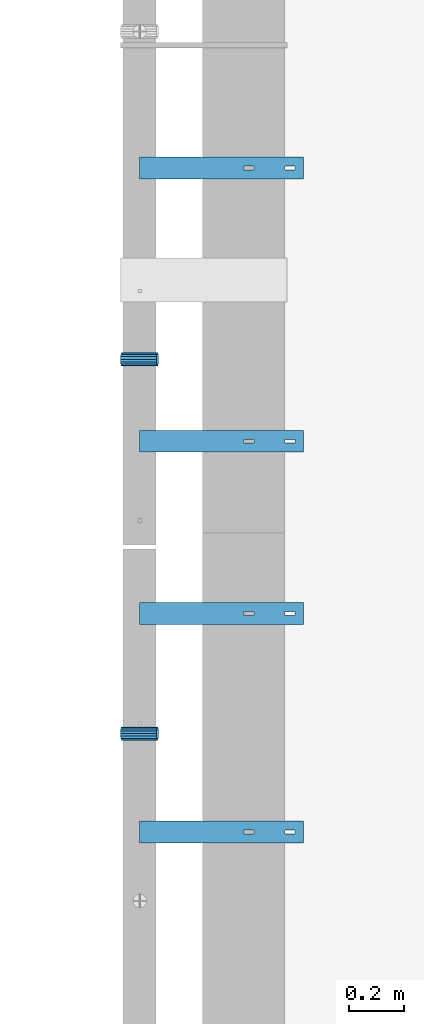
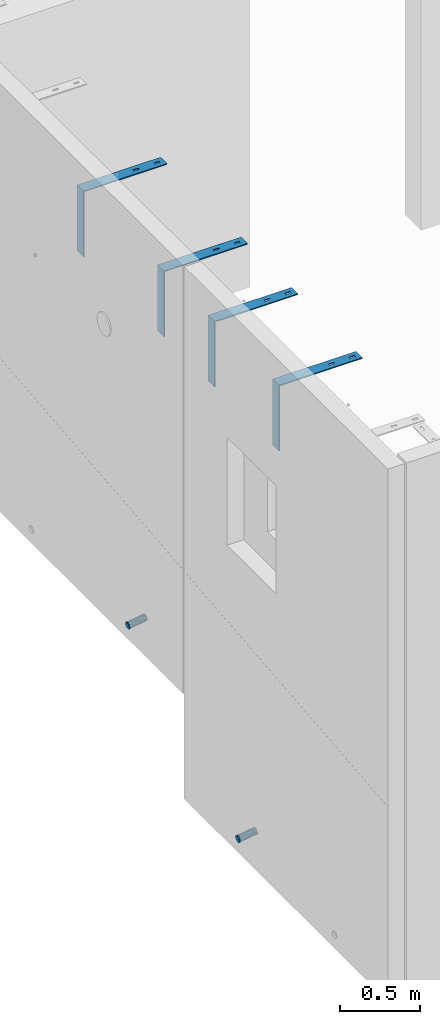
# One storey, part 85 of 264: 6 beams, 8 elements without a shape of their own.
"""IFC2X3 building model written with IfcOpenShell, lengths in millimetres."""

from ifc_helpers import new_model, si_unit, frame, origin_with_axes, place, context, subcontext, project, spatial, faceted_brep, material, type_object, element, aggregate, save


model = new_model("IFC2X3")

# Units and contexts
model_context = context("Model", 3, precision=1e-05, world=origin_with_axes())
body_context = subcontext(model_context, "Body", "Model", "MODEL_VIEW")
ifc_project = project(units=[si_unit("LENGTHUNIT", "METRE", prefix="MILLI"), si_unit("AREAUNIT", "SQUARE_METRE"), si_unit("VOLUMEUNIT", "CUBIC_METRE"), si_unit("MASSUNIT", "GRAM", prefix="KILO"), si_unit("TIMEUNIT", "SECOND"), si_unit("PLANEANGLEUNIT", "RADIAN"), si_unit("SOLIDANGLEUNIT", "STERADIAN"), si_unit("THERMODYNAMICTEMPERATUREUNIT", "DEGREE_CELSIUS"), si_unit("LUMINOUSINTENSITYUNIT", "LUMEN")], contexts=[model_context])

# Site, building, storey
site_placement = place(None, origin_with_axes())
site = spatial("IfcSite", under=ifc_project, at=site_placement, CompositionType="ELEMENT")
building_placement = place(site_placement, origin_with_axes())
building = spatial("IfcBuilding", under=site, at=building_placement, CompositionType="ELEMENT")
storey_placement = place(building_placement, origin_with_axes())
storey = spatial("IfcBuildingStorey", under=building, at=storey_placement, Name="K", CompositionType="ELEMENT", Elevation=0.0)

# Assemblies, beam
assembly_1_placement = place(storey_placement, origin_with_axes())
assembly_1 = element("IfcElementAssembly", 1, at=assembly_1_placement, inside=storey, AssemblyPlace="NOTDEFINED", PredefinedType="REINFORCEMENT_UNIT")
assembly_2_placement = place(assembly_1_placement, origin_with_axes())
assembly_2 = element("IfcElementAssembly", 2, at=assembly_2_placement, Name="Steel Assembly", AssemblyPlace="NOTDEFINED", PredefinedType="NOTDEFINED")
ifc_material_1 = material()
beam_type_1 = type_object("IfcBeamType", Name="D50", PredefinedType="NOTDEFINED")
beam_1_placement = place(assembly_2_placement, frame((7685.611109453, 13889.9999997536, 78614.7172983598), z_axis=(0.0, -1.0, 0.0), x_axis=(-0.988691934499859, -5.59999884149448e-08, -0.149960857075848)))
beam_1 = element("IfcBeam", 3, at=beam_1_placement, type_object=beam_type_1, material=ifc_material_1, ObjectType="D50", context=body_context, shape_type="Brep", body=[
    faceted_brep([(0.0, -25.0, 0.0), (-3.63797880709171e-12, -23.0969883127837, -9.56708580912891), (133.368135763521, -23.0969883127691, -9.56708580912709), (133.368135766923, -24.9999999999854, 1.81898940354586e-12), (-3.63797880709171e-12, -17.6776695296576, -17.6776695296649), (133.36813576064, -17.6776695296576, -17.677669529663), (-1.09139364212751e-11, -9.56708580913255, -23.0969883127837), (133.368135758712, -9.567085809118, -23.0969883127818), (-1.09139364212751e-11, 0.0, -25.0), (133.368135758034, 0.0, -25.0), (-1.09139364212751e-11, 9.56708580913255, -23.0969883127837), (133.36813575871, 9.56708580913255, -23.0969883127837), (-3.63797880709171e-12, 17.6776695296576, -17.6776695296649), (133.36813576064, 17.6776695296721, -17.677669529663), (-3.63797880709171e-12, 23.0969883127837, -9.56708580912891), (133.36813576352, 23.0969883127982, -9.56708580912709), (0.0, 25.0, 0.0), (133.368135766925, 25.0000000000146, -1.81898940354586e-12), (7.27595761418343e-12, 23.0969883127837, 9.56708580912891), (133.368135770323, 23.0969883127837, 9.56708580912709), (7.27595761418343e-12, 17.6776695296576, 17.6776695296649), (133.368135773204, 17.6776695296721, 17.6776695296649), (1.45519152283669e-11, 9.56708580913255, 23.0969883127837), (133.368135775132, 9.5670858091471, 23.0969883127837), (1.09139364212751e-11, 0.0, 25.0), (133.368135775807, 1.45519152283669e-11, 25.0), (1.45519152283669e-11, -9.56708580913255, 23.0969883127837), (133.368135775134, -9.56708580910345, 23.0969883127837), (7.27595761418343e-12, -17.6776695296576, 17.6776695296649), (133.368135773204, -17.6776695296721, 17.6776695296649), (7.27595761418343e-12, -23.0969883127837, 9.56708580912891), (133.368135770321, -23.0969883127691, 9.56708580912709)], [[[0, 1, 2, 3]], [[1, 4, 5, 2]], [[4, 6, 7, 5]], [[6, 8, 9, 7]], [[8, 10, 11, 9]], [[10, 12, 13, 11]], [[12, 14, 15, 13]], [[14, 16, 17, 15]], [[16, 18, 19, 17]], [[18, 20, 21, 19]], [[20, 22, 23, 21]], [[22, 24, 25, 23]], [[24, 26, 27, 25]], [[26, 28, 29, 27]], [[28, 30, 31, 29]], [[30, 0, 3, 31]], [[5, 7, 9, 11, 13, 15, 17, 19, 21, 23, 25, 27, 29, 31, 3, 2]], [[30, 28, 26, 24, 22, 20, 18, 16, 14, 12, 10, 8, 6, 4, 1, 0]]]),
])
aggregate(assembly_2, [beam_1])

assembly_3_placement = place(storey_placement, origin_with_axes())
assembly_3 = element("IfcElementAssembly", 4, at=assembly_3_placement, inside=storey, AssemblyPlace="NOTDEFINED", PredefinedType="REINFORCEMENT_UNIT")
assembly_4_placement = place(assembly_3_placement, origin_with_axes())
assembly_4 = element("IfcElementAssembly", 5, at=assembly_4_placement, Name="Steel Assembly", AssemblyPlace="NOTDEFINED", PredefinedType="NOTDEFINED")
beam_2_placement = place(assembly_4_placement, frame((7685.611109453, 12519.9999997536, 77824.7172983598), z_axis=(0.0, -1.0, 0.0), x_axis=(-0.988691934499859, -5.59999884149448e-08, -0.149960857075848)))
beam_2 = element("IfcBeam", 6, at=beam_2_placement, type_object=beam_type_1, material=ifc_material_1, ObjectType="D50", context=body_context, shape_type="Brep", body=[
    faceted_brep([(0.0, -25.0, 0.0), (-3.63797880709171e-12, -23.0969883127837, -9.56708580912891), (133.368135763521, -23.0969883127691, -9.56708580912709), (133.368135766923, -24.9999999999854, 1.81898940354586e-12), (-3.63797880709171e-12, -17.6776695296576, -17.6776695296649), (133.36813576064, -17.6776695296576, -17.677669529663), (-1.09139364212751e-11, -9.56708580913255, -23.0969883127837), (133.368135758712, -9.567085809118, -23.0969883127818), (-1.09139364212751e-11, 0.0, -25.0), (133.368135758034, 0.0, -25.0), (-1.09139364212751e-11, 9.56708580913255, -23.0969883127837), (133.36813575871, 9.56708580913255, -23.0969883127837), (-3.63797880709171e-12, 17.6776695296576, -17.6776695296649), (133.36813576064, 17.6776695296721, -17.677669529663), (-3.63797880709171e-12, 23.0969883127837, -9.56708580912891), (133.36813576352, 23.0969883127982, -9.56708580912709), (0.0, 25.0, 0.0), (133.368135766925, 25.0000000000146, -1.81898940354586e-12), (7.27595761418343e-12, 23.0969883127837, 9.56708580912891), (133.368135770323, 23.0969883127837, 9.56708580912709), (7.27595761418343e-12, 17.6776695296576, 17.6776695296649), (133.368135773204, 17.6776695296721, 17.6776695296649), (1.45519152283669e-11, 9.56708580913255, 23.0969883127837), (133.368135775132, 9.5670858091471, 23.0969883127837), (1.09139364212751e-11, 0.0, 25.0), (133.368135775807, 1.45519152283669e-11, 25.0), (1.45519152283669e-11, -9.56708580913255, 23.0969883127837), (133.368135775134, -9.56708580910345, 23.0969883127837), (7.27595761418343e-12, -17.6776695296576, 17.6776695296649), (133.368135773204, -17.6776695296721, 17.6776695296649), (7.27595761418343e-12, -23.0969883127837, 9.56708580912891), (133.368135770321, -23.0969883127691, 9.56708580912709)], [[[0, 1, 2, 3]], [[1, 4, 5, 2]], [[4, 6, 7, 5]], [[6, 8, 9, 7]], [[8, 10, 11, 9]], [[10, 12, 13, 11]], [[12, 14, 15, 13]], [[14, 16, 17, 15]], [[16, 18, 19, 17]], [[18, 20, 21, 19]], [[20, 22, 23, 21]], [[22, 24, 25, 23]], [[24, 26, 27, 25]], [[26, 28, 29, 27]], [[28, 30, 31, 29]], [[30, 0, 3, 31]], [[5, 7, 9, 11, 13, 15, 17, 19, 21, 23, 25, 27, 29, 31, 3, 2]], [[30, 28, 26, 24, 22, 20, 18, 16, 14, 12, 10, 8, 6, 4, 1, 0]]]),
])
aggregate(assembly_4, [beam_2])

# Assembly, beam
assembly_5_placement = place(assembly_1_placement, origin_with_axes())
assembly_5 = element("IfcElementAssembly", 7, at=assembly_5_placement, Name="Steel Assembly", AssemblyPlace="NOTDEFINED", PredefinedType="RIGID_FRAME")
ifc_material_2 = material(Name="STEEL/1.4301")
beam_type_2 = type_object("IfcBeamType", PredefinedType="NOTDEFINED")
beam_3_placement = place(assembly_5_placement, frame((7920.0, 14550.0, 81220.0), z_axis=(1.0, 0.0, 0.0), x_axis=(0.0, 1.0, 0.0)))
beam_3 = element("IfcBeam", 8, at=beam_3_placement, type_object=beam_type_2, material=ifc_material_2, Name="RST", context=body_context, shape_type="Brep", body=[
    faceted_brep([(41.9999999999854, 250.0, 119.999999999996), (41.9999999999854, 242.0, 119.999999999996), (37.9999999999854, 242.0, 119.999999999996), (37.9999999999854, 250.0, 119.999999999996), (36.4549150281109, 242.0, 119.755282581471), (36.4549150281109, 250.0, 119.755282581471), (35.0610737385232, 242.0, 119.045084971873), (35.0610737385232, 250.0, 119.045084971873), (33.9549150281109, 242.0, 117.93892626146), (33.9549150281109, 250.0, 117.93892626146), (33.244717418509, 242.0, 116.545084971873), (33.244717418509, 250.0, 116.545084971873), (32.9999999999854, 242.0, 114.999999999996), (32.9999999999854, 250.0, 114.999999999996), (32.9999999999854, 242.0, 84.9999999999964), (32.9999999999854, 250.0, 84.9999999999964), (33.244717418509, 242.0, 83.4549150281237), (33.244717418509, 250.0, 83.4549150281237), (33.9549150281109, 242.0, 82.0610737385359), (33.9549150281109, 250.0, 82.0610737385359), (35.0610737385232, 242.0, 80.9549150281237), (35.0610737385232, 250.0, 80.9549150281237), (36.4549150281109, 242.0, 80.2447174185218), (36.4549150281109, 250.0, 80.2447174185218), (37.9999999999854, 242.0, 79.9999999999964), (37.9999999999854, 250.0, 79.9999999999964), (41.9999999999854, 242.0, 79.9999999999964), (41.9999999999854, 250.0, 79.9999999999964), (43.54508497186, 242.0, 80.2447174185218), (43.54508497186, 250.0, 80.2447174185218), (44.9389262614477, 242.0, 80.9549150281237), (44.9389262614477, 250.0, 80.9549150281237), (46.04508497186, 242.0, 82.0610737385359), (46.04508497186, 250.0, 82.0610737385359), (46.7552825814619, 242.0, 83.4549150281237), (46.7552825814619, 250.0, 83.4549150281237), (46.9999999999854, 242.0, 84.9999999999964), (46.9999999999854, 250.0, 84.9999999999964), (46.9999999999854, 242.0, 114.999999999996), (46.9999999999854, 250.0, 114.999999999996), (46.7552825814619, 242.0, 116.545084971873), (46.7552825814619, 250.0, 116.545084971873), (46.04508497186, 242.0, 117.93892626146), (46.04508497186, 250.0, 117.93892626146), (44.9389262614477, 242.0, 119.045084971873), (44.9389262614477, 250.0, 119.045084971873), (43.54508497186, 242.0, 119.755282581471), (43.54508497186, 250.0, 119.755282581471), (0.0, -250.0, -292.0), (0.0, -250.0, -300.0), (80.0, -250.0, -300.0), (80.0, -250.0, -292.0), (0.0, 242.0, -292.0), (80.0, 242.0, -292.0), (0.0, 250.0, 300.0), (0.0, 242.0, 300.0), (80.0, 242.0, 300.0), (80.0, 250.0, 300.0), (0.0, 250.0, -300.0), (80.0, 250.0, -300.0), (46.9999999999854, 250.0, 264.999999999996), (46.7552825814619, 250.0, 266.545084971873), (46.04508497186, 250.0, 267.93892626146), (44.9389262614477, 250.0, 269.045084971873), (43.54508497186, 250.0, 269.755282581471), (41.9999999999854, 250.0, 269.999999999996), (37.9999999999854, 250.0, 269.999999999996), (36.4549150281109, 250.0, 269.755282581471), (35.0610737385232, 250.0, 269.045084971873), (33.9549150281109, 250.0, 267.93892626146), (33.244717418509, 250.0, 266.545084971873), (32.9999999999854, 250.0, 264.999999999996), (32.9999999999854, 250.0, 234.999999999996), (33.244717418509, 250.0, 233.454915028124), (33.9549150281109, 250.0, 232.061073738536), (35.0610737385232, 250.0, 230.954915028124), (36.4549150281109, 250.0, 230.244717418522), (37.9999999999854, 250.0, 229.999999999996), (41.9999999999854, 250.0, 229.999999999996), (43.54508497186, 250.0, 230.244717418522), (44.9389262614477, 250.0, 230.954915028124), (46.04508497186, 250.0, 232.061073738536), (46.7552825814619, 250.0, 233.454915028124), (46.9999999999854, 250.0, 234.999999999996), (46.04508497186, 242.0, 267.93892626146), (44.9389262614477, 242.0, 269.045084971873), (46.7552825814619, 242.0, 266.545084971873), (46.9999999999854, 242.0, 264.999999999996), (46.9999999999854, 242.0, 234.999999999996), (46.7552825814619, 242.0, 233.454915028124), (46.04508497186, 242.0, 232.061073738536), (44.9389262614477, 242.0, 230.954915028124), (43.54508497186, 242.0, 230.244717418522), (41.9999999999854, 242.0, 229.999999999996), (37.9999999999854, 242.0, 229.999999999996), (36.4549150281109, 242.0, 230.244717418522), (35.0610737385232, 242.0, 230.954915028124), (33.9549150281109, 242.0, 232.061073738536), (33.244717418509, 242.0, 233.454915028124), (32.9999999999854, 242.0, 234.999999999996), (32.9999999999854, 242.0, 264.999999999996), (33.244717418509, 242.0, 266.545084971873), (33.9549150281109, 242.0, 267.93892626146), (35.0610737385232, 242.0, 269.045084971873), (36.4549150281109, 242.0, 269.755282581471), (37.9999999999854, 242.0, 269.999999999996), (41.9999999999854, 242.0, 269.999999999996), (43.54508497186, 242.0, 269.755282581471)], [[[0, 1, 2, 3]], [[3, 2, 4, 5]], [[5, 4, 6, 7]], [[7, 6, 8, 9]], [[9, 8, 10, 11]], [[11, 10, 12, 13]], [[13, 12, 14, 15]], [[15, 14, 16, 17]], [[17, 16, 18, 19]], [[19, 18, 20, 21]], [[21, 20, 22, 23]], [[23, 22, 24, 25]], [[25, 24, 26, 27]], [[27, 26, 28, 29]], [[29, 28, 30, 31]], [[31, 30, 32, 33]], [[33, 32, 34, 35]], [[35, 34, 36, 37]], [[37, 36, 38, 39]], [[39, 38, 40, 41]], [[41, 40, 42, 43]], [[43, 42, 44, 45]], [[45, 44, 46, 47]], [[47, 46, 1, 0]], [[48, 49, 50, 51]], [[52, 48, 51, 53]], [[54, 55, 56, 57]], [[49, 48, 52, 55, 54, 58]], [[49, 58, 59, 50]], [[56, 53, 51, 50, 59, 57]], [[58, 54, 57, 59], [39, 41, 43, 45, 47, 0, 3, 5, 7, 9, 11, 13, 15, 17, 19, 21, 23, 25, 27, 29, 31, 33, 35, 37], [60, 61, 62, 63, 64, 65, 66, 67, 68, 69, 70, 71, 72, 73, 74, 75, 76, 77, 78, 79, 80, 81, 82, 83]], [[62, 84, 85, 63]], [[61, 86, 84, 62]], [[60, 87, 86, 61]], [[83, 88, 87, 60]], [[82, 89, 88, 83]], [[81, 90, 89, 82]], [[80, 91, 90, 81]], [[79, 92, 91, 80]], [[78, 93, 92, 79]], [[77, 94, 93, 78]], [[76, 95, 94, 77]], [[75, 96, 95, 76]], [[74, 97, 96, 75]], [[73, 98, 97, 74]], [[72, 99, 98, 73]], [[71, 100, 99, 72]], [[70, 101, 100, 71]], [[69, 102, 101, 70]], [[68, 103, 102, 69]], [[67, 104, 103, 68]], [[66, 105, 104, 67]], [[65, 106, 105, 66]], [[64, 107, 106, 65]], [[63, 85, 107, 64]], [[55, 52, 53, 56], [30, 28, 26, 24, 22, 20, 18, 16, 14, 12, 10, 8, 6, 4, 2, 1, 46, 44, 42, 40, 38, 36, 34, 32], [91, 92, 93, 94, 95, 96, 97, 98, 99, 100, 101, 102, 103, 104, 105, 106, 107, 85, 84, 86, 87, 88, 89, 90]]]),
])
aggregate(assembly_5, [beam_3])

# Assembly
assembly_6_placement = place(assembly_1_placement, origin_with_axes())
assembly_6 = element("IfcElementAssembly", 9, at=assembly_6_placement, Name="Steel Assembly", AssemblyPlace="NOTDEFINED", PredefinedType="RIGID_FRAME")

aggregate(assembly_1, [assembly_5, assembly_6, assembly_2])

# Beam
beam_4_placement = place(assembly_6_placement, frame((7920.0, 13550.0, 81220.0), z_axis=(1.0, 0.0, 0.0), x_axis=(0.0, 1.0, 0.0)))
beam_4 = element("IfcBeam", 10, at=beam_4_placement, type_object=beam_type_2, material=ifc_material_2, Name="RST", context=body_context, shape_type="Brep", body=[
    faceted_brep([(41.9999999999854, 250.0, 119.999999999996), (41.9999999999854, 242.0, 119.999999999996), (37.9999999999854, 242.0, 119.999999999996), (37.9999999999854, 250.0, 119.999999999996), (36.4549150281109, 242.0, 119.755282581471), (36.4549150281109, 250.0, 119.755282581471), (35.0610737385232, 242.0, 119.045084971873), (35.0610737385232, 250.0, 119.045084971873), (33.9549150281109, 242.0, 117.93892626146), (33.9549150281109, 250.0, 117.93892626146), (33.244717418509, 242.0, 116.545084971873), (33.244717418509, 250.0, 116.545084971873), (32.9999999999854, 242.0, 114.999999999996), (32.9999999999854, 250.0, 114.999999999996), (32.9999999999854, 242.0, 84.9999999999964), (32.9999999999854, 250.0, 84.9999999999964), (33.244717418509, 242.0, 83.4549150281237), (33.244717418509, 250.0, 83.4549150281237), (33.9549150281109, 242.0, 82.0610737385359), (33.9549150281109, 250.0, 82.0610737385359), (35.0610737385232, 242.0, 80.9549150281237), (35.0610737385232, 250.0, 80.9549150281237), (36.4549150281109, 242.0, 80.2447174185218), (36.4549150281109, 250.0, 80.2447174185218), (37.9999999999854, 242.0, 79.9999999999964), (37.9999999999854, 250.0, 79.9999999999964), (41.9999999999854, 242.0, 79.9999999999964), (41.9999999999854, 250.0, 79.9999999999964), (43.54508497186, 242.0, 80.2447174185218), (43.54508497186, 250.0, 80.2447174185218), (44.9389262614477, 242.0, 80.9549150281237), (44.9389262614477, 250.0, 80.9549150281237), (46.04508497186, 242.0, 82.0610737385359), (46.04508497186, 250.0, 82.0610737385359), (46.7552825814619, 242.0, 83.4549150281237), (46.7552825814619, 250.0, 83.4549150281237), (46.9999999999854, 242.0, 84.9999999999964), (46.9999999999854, 250.0, 84.9999999999964), (46.9999999999854, 242.0, 114.999999999996), (46.9999999999854, 250.0, 114.999999999996), (46.7552825814619, 242.0, 116.545084971873), (46.7552825814619, 250.0, 116.545084971873), (46.04508497186, 242.0, 117.93892626146), (46.04508497186, 250.0, 117.93892626146), (44.9389262614477, 242.0, 119.045084971873), (44.9389262614477, 250.0, 119.045084971873), (43.54508497186, 242.0, 119.755282581471), (43.54508497186, 250.0, 119.755282581471), (0.0, -250.0, -292.0), (0.0, -250.0, -300.0), (80.0, -250.0, -300.0), (80.0, -250.0, -292.0), (0.0, 242.0, -292.0), (80.0, 242.0, -292.0), (0.0, 250.0, 300.0), (0.0, 242.0, 300.0), (80.0, 242.0, 300.0), (80.0, 250.0, 300.0), (0.0, 250.0, -300.0), (80.0, 250.0, -300.0), (46.9999999999854, 250.0, 264.999999999996), (46.7552825814619, 250.0, 266.545084971873), (46.04508497186, 250.0, 267.93892626146), (44.9389262614477, 250.0, 269.045084971873), (43.54508497186, 250.0, 269.755282581471), (41.9999999999854, 250.0, 269.999999999996), (37.9999999999854, 250.0, 269.999999999996), (36.4549150281109, 250.0, 269.755282581471), (35.0610737385232, 250.0, 269.045084971873), (33.9549150281109, 250.0, 267.93892626146), (33.244717418509, 250.0, 266.545084971873), (32.9999999999854, 250.0, 264.999999999996), (32.9999999999854, 250.0, 234.999999999996), (33.244717418509, 250.0, 233.454915028124), (33.9549150281109, 250.0, 232.061073738536), (35.0610737385232, 250.0, 230.954915028124), (36.4549150281109, 250.0, 230.244717418522), (37.9999999999854, 250.0, 229.999999999996), (41.9999999999854, 250.0, 229.999999999996), (43.54508497186, 250.0, 230.244717418522), (44.9389262614477, 250.0, 230.954915028124), (46.04508497186, 250.0, 232.061073738536), (46.7552825814619, 250.0, 233.454915028124), (46.9999999999854, 250.0, 234.999999999996), (46.04508497186, 242.0, 267.93892626146), (44.9389262614477, 242.0, 269.045084971873), (46.7552825814619, 242.0, 266.545084971873), (46.9999999999854, 242.0, 264.999999999996), (46.9999999999854, 242.0, 234.999999999996), (46.7552825814619, 242.0, 233.454915028124), (46.04508497186, 242.0, 232.061073738536), (44.9389262614477, 242.0, 230.954915028124), (43.54508497186, 242.0, 230.244717418522), (41.9999999999854, 242.0, 229.999999999996), (37.9999999999854, 242.0, 229.999999999996), (36.4549150281109, 242.0, 230.244717418522), (35.0610737385232, 242.0, 230.954915028124), (33.9549150281109, 242.0, 232.061073738536), (33.244717418509, 242.0, 233.454915028124), (32.9999999999854, 242.0, 234.999999999996), (32.9999999999854, 242.0, 264.999999999996), (33.244717418509, 242.0, 266.545084971873), (33.9549150281109, 242.0, 267.93892626146), (35.0610737385232, 242.0, 269.045084971873), (36.4549150281109, 242.0, 269.755282581471), (37.9999999999854, 242.0, 269.999999999996), (41.9999999999854, 242.0, 269.999999999996), (43.54508497186, 242.0, 269.755282581471)], [[[0, 1, 2, 3]], [[3, 2, 4, 5]], [[5, 4, 6, 7]], [[7, 6, 8, 9]], [[9, 8, 10, 11]], [[11, 10, 12, 13]], [[13, 12, 14, 15]], [[15, 14, 16, 17]], [[17, 16, 18, 19]], [[19, 18, 20, 21]], [[21, 20, 22, 23]], [[23, 22, 24, 25]], [[25, 24, 26, 27]], [[27, 26, 28, 29]], [[29, 28, 30, 31]], [[31, 30, 32, 33]], [[33, 32, 34, 35]], [[35, 34, 36, 37]], [[37, 36, 38, 39]], [[39, 38, 40, 41]], [[41, 40, 42, 43]], [[43, 42, 44, 45]], [[45, 44, 46, 47]], [[47, 46, 1, 0]], [[48, 49, 50, 51]], [[52, 48, 51, 53]], [[54, 55, 56, 57]], [[49, 48, 52, 55, 54, 58]], [[49, 58, 59, 50]], [[56, 53, 51, 50, 59, 57]], [[58, 54, 57, 59], [39, 41, 43, 45, 47, 0, 3, 5, 7, 9, 11, 13, 15, 17, 19, 21, 23, 25, 27, 29, 31, 33, 35, 37], [60, 61, 62, 63, 64, 65, 66, 67, 68, 69, 70, 71, 72, 73, 74, 75, 76, 77, 78, 79, 80, 81, 82, 83]], [[62, 84, 85, 63]], [[61, 86, 84, 62]], [[60, 87, 86, 61]], [[83, 88, 87, 60]], [[82, 89, 88, 83]], [[81, 90, 89, 82]], [[80, 91, 90, 81]], [[79, 92, 91, 80]], [[78, 93, 92, 79]], [[77, 94, 93, 78]], [[76, 95, 94, 77]], [[75, 96, 95, 76]], [[74, 97, 96, 75]], [[73, 98, 97, 74]], [[72, 99, 98, 73]], [[71, 100, 99, 72]], [[70, 101, 100, 71]], [[69, 102, 101, 70]], [[68, 103, 102, 69]], [[67, 104, 103, 68]], [[66, 105, 104, 67]], [[65, 106, 105, 66]], [[64, 107, 106, 65]], [[63, 85, 107, 64]], [[55, 52, 53, 56], [30, 28, 26, 24, 22, 20, 18, 16, 14, 12, 10, 8, 6, 4, 2, 1, 46, 44, 42, 40, 38, 36, 34, 32], [91, 92, 93, 94, 95, 96, 97, 98, 99, 100, 101, 102, 103, 104, 105, 106, 107, 85, 84, 86, 87, 88, 89, 90]]]),
])

aggregate(assembly_6, [beam_4])

# Assembly, beam
assembly_7_placement = place(assembly_3_placement, origin_with_axes())
assembly_7 = element("IfcElementAssembly", 11, at=assembly_7_placement, Name="Steel Assembly", AssemblyPlace="NOTDEFINED", PredefinedType="RIGID_FRAME")
beam_5_placement = place(assembly_7_placement, frame((7920.0, 12920.0, 81220.0), z_axis=(1.0, 0.0, 0.0), x_axis=(0.0, 1.0, 0.0)))
beam_5 = element("IfcBeam", 12, at=beam_5_placement, type_object=beam_type_2, material=ifc_material_2, Name="RST", context=body_context, shape_type="Brep", body=[
    faceted_brep([(41.9999999999854, 250.0, 119.999999999996), (41.9999999999854, 242.0, 119.999999999996), (37.9999999999854, 242.0, 119.999999999996), (37.9999999999854, 250.0, 119.999999999996), (36.4549150281109, 242.0, 119.755282581471), (36.4549150281109, 250.0, 119.755282581471), (35.0610737385232, 242.0, 119.045084971873), (35.0610737385232, 250.0, 119.045084971873), (33.9549150281109, 242.0, 117.93892626146), (33.9549150281109, 250.0, 117.93892626146), (33.244717418509, 242.0, 116.545084971873), (33.244717418509, 250.0, 116.545084971873), (32.9999999999854, 242.0, 114.999999999996), (32.9999999999854, 250.0, 114.999999999996), (32.9999999999854, 242.0, 84.9999999999964), (32.9999999999854, 250.0, 84.9999999999964), (33.244717418509, 242.0, 83.4549150281237), (33.244717418509, 250.0, 83.4549150281237), (33.9549150281109, 242.0, 82.0610737385359), (33.9549150281109, 250.0, 82.0610737385359), (35.0610737385232, 242.0, 80.9549150281237), (35.0610737385232, 250.0, 80.9549150281237), (36.4549150281109, 242.0, 80.2447174185218), (36.4549150281109, 250.0, 80.2447174185218), (37.9999999999854, 242.0, 79.9999999999964), (37.9999999999854, 250.0, 79.9999999999964), (41.9999999999854, 242.0, 79.9999999999964), (41.9999999999854, 250.0, 79.9999999999964), (43.54508497186, 242.0, 80.2447174185218), (43.54508497186, 250.0, 80.2447174185218), (44.9389262614477, 242.0, 80.9549150281237), (44.9389262614477, 250.0, 80.9549150281237), (46.04508497186, 242.0, 82.0610737385359), (46.04508497186, 250.0, 82.0610737385359), (46.7552825814619, 242.0, 83.4549150281237), (46.7552825814619, 250.0, 83.4549150281237), (46.9999999999854, 242.0, 84.9999999999964), (46.9999999999854, 250.0, 84.9999999999964), (46.9999999999854, 242.0, 114.999999999996), (46.9999999999854, 250.0, 114.999999999996), (46.7552825814619, 242.0, 116.545084971873), (46.7552825814619, 250.0, 116.545084971873), (46.04508497186, 242.0, 117.93892626146), (46.04508497186, 250.0, 117.93892626146), (44.9389262614477, 242.0, 119.045084971873), (44.9389262614477, 250.0, 119.045084971873), (43.54508497186, 242.0, 119.755282581471), (43.54508497186, 250.0, 119.755282581471), (0.0, -250.0, -292.0), (0.0, -250.0, -300.0), (80.0, -250.0, -300.0), (80.0, -250.0, -292.0), (0.0, 242.0, -292.0), (80.0, 242.0, -292.0), (0.0, 250.0, 300.0), (0.0, 242.0, 300.0), (80.0, 242.0, 300.0), (80.0, 250.0, 300.0), (0.0, 250.0, -300.0), (80.0, 250.0, -300.0), (46.9999999999854, 250.0, 264.999999999996), (46.7552825814619, 250.0, 266.545084971873), (46.04508497186, 250.0, 267.93892626146), (44.9389262614477, 250.0, 269.045084971873), (43.54508497186, 250.0, 269.755282581471), (41.9999999999854, 250.0, 269.999999999996), (37.9999999999854, 250.0, 269.999999999996), (36.4549150281109, 250.0, 269.755282581471), (35.0610737385232, 250.0, 269.045084971873), (33.9549150281109, 250.0, 267.93892626146), (33.244717418509, 250.0, 266.545084971873), (32.9999999999854, 250.0, 264.999999999996), (32.9999999999854, 250.0, 234.999999999996), (33.244717418509, 250.0, 233.454915028124), (33.9549150281109, 250.0, 232.061073738536), (35.0610737385232, 250.0, 230.954915028124), (36.4549150281109, 250.0, 230.244717418522), (37.9999999999854, 250.0, 229.999999999996), (41.9999999999854, 250.0, 229.999999999996), (43.54508497186, 250.0, 230.244717418522), (44.9389262614477, 250.0, 230.954915028124), (46.04508497186, 250.0, 232.061073738536), (46.7552825814619, 250.0, 233.454915028124), (46.9999999999854, 250.0, 234.999999999996), (46.04508497186, 242.0, 267.93892626146), (44.9389262614477, 242.0, 269.045084971873), (46.7552825814619, 242.0, 266.545084971873), (46.9999999999854, 242.0, 264.999999999996), (46.9999999999854, 242.0, 234.999999999996), (46.7552825814619, 242.0, 233.454915028124), (46.04508497186, 242.0, 232.061073738536), (44.9389262614477, 242.0, 230.954915028124), (43.54508497186, 242.0, 230.244717418522), (41.9999999999854, 242.0, 229.999999999996), (37.9999999999854, 242.0, 229.999999999996), (36.4549150281109, 242.0, 230.244717418522), (35.0610737385232, 242.0, 230.954915028124), (33.9549150281109, 242.0, 232.061073738536), (33.244717418509, 242.0, 233.454915028124), (32.9999999999854, 242.0, 234.999999999996), (32.9999999999854, 242.0, 264.999999999996), (33.244717418509, 242.0, 266.545084971873), (33.9549150281109, 242.0, 267.93892626146), (35.0610737385232, 242.0, 269.045084971873), (36.4549150281109, 242.0, 269.755282581471), (37.9999999999854, 242.0, 269.999999999996), (41.9999999999854, 242.0, 269.999999999996), (43.54508497186, 242.0, 269.755282581471)], [[[0, 1, 2, 3]], [[3, 2, 4, 5]], [[5, 4, 6, 7]], [[7, 6, 8, 9]], [[9, 8, 10, 11]], [[11, 10, 12, 13]], [[13, 12, 14, 15]], [[15, 14, 16, 17]], [[17, 16, 18, 19]], [[19, 18, 20, 21]], [[21, 20, 22, 23]], [[23, 22, 24, 25]], [[25, 24, 26, 27]], [[27, 26, 28, 29]], [[29, 28, 30, 31]], [[31, 30, 32, 33]], [[33, 32, 34, 35]], [[35, 34, 36, 37]], [[37, 36, 38, 39]], [[39, 38, 40, 41]], [[41, 40, 42, 43]], [[43, 42, 44, 45]], [[45, 44, 46, 47]], [[47, 46, 1, 0]], [[48, 49, 50, 51]], [[52, 48, 51, 53]], [[54, 55, 56, 57]], [[49, 48, 52, 55, 54, 58]], [[49, 58, 59, 50]], [[56, 53, 51, 50, 59, 57]], [[58, 54, 57, 59], [39, 41, 43, 45, 47, 0, 3, 5, 7, 9, 11, 13, 15, 17, 19, 21, 23, 25, 27, 29, 31, 33, 35, 37], [60, 61, 62, 63, 64, 65, 66, 67, 68, 69, 70, 71, 72, 73, 74, 75, 76, 77, 78, 79, 80, 81, 82, 83]], [[62, 84, 85, 63]], [[61, 86, 84, 62]], [[60, 87, 86, 61]], [[83, 88, 87, 60]], [[82, 89, 88, 83]], [[81, 90, 89, 82]], [[80, 91, 90, 81]], [[79, 92, 91, 80]], [[78, 93, 92, 79]], [[77, 94, 93, 78]], [[76, 95, 94, 77]], [[75, 96, 95, 76]], [[74, 97, 96, 75]], [[73, 98, 97, 74]], [[72, 99, 98, 73]], [[71, 100, 99, 72]], [[70, 101, 100, 71]], [[69, 102, 101, 70]], [[68, 103, 102, 69]], [[67, 104, 103, 68]], [[66, 105, 104, 67]], [[65, 106, 105, 66]], [[64, 107, 106, 65]], [[63, 85, 107, 64]], [[55, 52, 53, 56], [30, 28, 26, 24, 22, 20, 18, 16, 14, 12, 10, 8, 6, 4, 2, 1, 46, 44, 42, 40, 38, 36, 34, 32], [91, 92, 93, 94, 95, 96, 97, 98, 99, 100, 101, 102, 103, 104, 105, 106, 107, 85, 84, 86, 87, 88, 89, 90]]]),
])
aggregate(assembly_7, [beam_5])

# Assembly
assembly_8_placement = place(assembly_3_placement, origin_with_axes())
assembly_8 = element("IfcElementAssembly", 13, at=assembly_8_placement, Name="Steel Assembly", AssemblyPlace="NOTDEFINED", PredefinedType="RIGID_FRAME")

aggregate(assembly_3, [assembly_7, assembly_8, assembly_4])

# Beam
beam_6_placement = place(assembly_8_placement, frame((7920.0, 12120.0, 81220.0), z_axis=(1.0, 0.0, 0.0), x_axis=(0.0, 1.0, 0.0)))
beam_6 = element("IfcBeam", 14, at=beam_6_placement, type_object=beam_type_2, material=ifc_material_2, Name="RST", context=body_context, shape_type="Brep", body=[
    faceted_brep([(41.9999999999854, 250.0, 119.999999999996), (41.9999999999854, 242.0, 119.999999999996), (37.9999999999854, 242.0, 119.999999999996), (37.9999999999854, 250.0, 119.999999999996), (36.4549150281109, 242.0, 119.755282581471), (36.4549150281109, 250.0, 119.755282581471), (35.0610737385232, 242.0, 119.045084971873), (35.0610737385232, 250.0, 119.045084971873), (33.9549150281109, 242.0, 117.93892626146), (33.9549150281109, 250.0, 117.93892626146), (33.244717418509, 242.0, 116.545084971873), (33.244717418509, 250.0, 116.545084971873), (32.9999999999854, 242.0, 114.999999999996), (32.9999999999854, 250.0, 114.999999999996), (32.9999999999854, 242.0, 84.9999999999964), (32.9999999999854, 250.0, 84.9999999999964), (33.244717418509, 242.0, 83.4549150281237), (33.244717418509, 250.0, 83.4549150281237), (33.9549150281109, 242.0, 82.0610737385359), (33.9549150281109, 250.0, 82.0610737385359), (35.0610737385232, 242.0, 80.9549150281237), (35.0610737385232, 250.0, 80.9549150281237), (36.4549150281109, 242.0, 80.2447174185218), (36.4549150281109, 250.0, 80.2447174185218), (37.9999999999854, 242.0, 79.9999999999964), (37.9999999999854, 250.0, 79.9999999999964), (41.9999999999854, 242.0, 79.9999999999964), (41.9999999999854, 250.0, 79.9999999999964), (43.54508497186, 242.0, 80.2447174185218), (43.54508497186, 250.0, 80.2447174185218), (44.9389262614477, 242.0, 80.9549150281237), (44.9389262614477, 250.0, 80.9549150281237), (46.04508497186, 242.0, 82.0610737385359), (46.04508497186, 250.0, 82.0610737385359), (46.7552825814619, 242.0, 83.4549150281237), (46.7552825814619, 250.0, 83.4549150281237), (46.9999999999854, 242.0, 84.9999999999964), (46.9999999999854, 250.0, 84.9999999999964), (46.9999999999854, 242.0, 114.999999999996), (46.9999999999854, 250.0, 114.999999999996), (46.7552825814619, 242.0, 116.545084971873), (46.7552825814619, 250.0, 116.545084971873), (46.04508497186, 242.0, 117.93892626146), (46.04508497186, 250.0, 117.93892626146), (44.9389262614477, 242.0, 119.045084971873), (44.9389262614477, 250.0, 119.045084971873), (43.54508497186, 242.0, 119.755282581471), (43.54508497186, 250.0, 119.755282581471), (0.0, -250.0, -292.0), (0.0, -250.0, -300.0), (80.0, -250.0, -300.0), (80.0, -250.0, -292.0), (0.0, 242.0, -292.0), (80.0, 242.0, -292.0), (0.0, 250.0, 300.0), (0.0, 242.0, 300.0), (80.0, 242.0, 300.0), (80.0, 250.0, 300.0), (0.0, 250.0, -300.0), (80.0, 250.0, -300.0), (46.9999999999854, 250.0, 264.999999999996), (46.7552825814619, 250.0, 266.545084971873), (46.04508497186, 250.0, 267.93892626146), (44.9389262614477, 250.0, 269.045084971873), (43.54508497186, 250.0, 269.755282581471), (41.9999999999854, 250.0, 269.999999999996), (37.9999999999854, 250.0, 269.999999999996), (36.4549150281109, 250.0, 269.755282581471), (35.0610737385232, 250.0, 269.045084971873), (33.9549150281109, 250.0, 267.93892626146), (33.244717418509, 250.0, 266.545084971873), (32.9999999999854, 250.0, 264.999999999996), (32.9999999999854, 250.0, 234.999999999996), (33.244717418509, 250.0, 233.454915028124), (33.9549150281109, 250.0, 232.061073738536), (35.0610737385232, 250.0, 230.954915028124), (36.4549150281109, 250.0, 230.244717418522), (37.9999999999854, 250.0, 229.999999999996), (41.9999999999854, 250.0, 229.999999999996), (43.54508497186, 250.0, 230.244717418522), (44.9389262614477, 250.0, 230.954915028124), (46.04508497186, 250.0, 232.061073738536), (46.7552825814619, 250.0, 233.454915028124), (46.9999999999854, 250.0, 234.999999999996), (46.04508497186, 242.0, 267.93892626146), (44.9389262614477, 242.0, 269.045084971873), (46.7552825814619, 242.0, 266.545084971873), (46.9999999999854, 242.0, 264.999999999996), (46.9999999999854, 242.0, 234.999999999996), (46.7552825814619, 242.0, 233.454915028124), (46.04508497186, 242.0, 232.061073738536), (44.9389262614477, 242.0, 230.954915028124), (43.54508497186, 242.0, 230.244717418522), (41.9999999999854, 242.0, 229.999999999996), (37.9999999999854, 242.0, 229.999999999996), (36.4549150281109, 242.0, 230.244717418522), (35.0610737385232, 242.0, 230.954915028124), (33.9549150281109, 242.0, 232.061073738536), (33.244717418509, 242.0, 233.454915028124), (32.9999999999854, 242.0, 234.999999999996), (32.9999999999854, 242.0, 264.999999999996), (33.244717418509, 242.0, 266.545084971873), (33.9549150281109, 242.0, 267.93892626146), (35.0610737385232, 242.0, 269.045084971873), (36.4549150281109, 242.0, 269.755282581471), (37.9999999999854, 242.0, 269.999999999996), (41.9999999999854, 242.0, 269.999999999996), (43.54508497186, 242.0, 269.755282581471)], [[[0, 1, 2, 3]], [[3, 2, 4, 5]], [[5, 4, 6, 7]], [[7, 6, 8, 9]], [[9, 8, 10, 11]], [[11, 10, 12, 13]], [[13, 12, 14, 15]], [[15, 14, 16, 17]], [[17, 16, 18, 19]], [[19, 18, 20, 21]], [[21, 20, 22, 23]], [[23, 22, 24, 25]], [[25, 24, 26, 27]], [[27, 26, 28, 29]], [[29, 28, 30, 31]], [[31, 30, 32, 33]], [[33, 32, 34, 35]], [[35, 34, 36, 37]], [[37, 36, 38, 39]], [[39, 38, 40, 41]], [[41, 40, 42, 43]], [[43, 42, 44, 45]], [[45, 44, 46, 47]], [[47, 46, 1, 0]], [[48, 49, 50, 51]], [[52, 48, 51, 53]], [[54, 55, 56, 57]], [[49, 48, 52, 55, 54, 58]], [[49, 58, 59, 50]], [[56, 53, 51, 50, 59, 57]], [[58, 54, 57, 59], [39, 41, 43, 45, 47, 0, 3, 5, 7, 9, 11, 13, 15, 17, 19, 21, 23, 25, 27, 29, 31, 33, 35, 37], [60, 61, 62, 63, 64, 65, 66, 67, 68, 69, 70, 71, 72, 73, 74, 75, 76, 77, 78, 79, 80, 81, 82, 83]], [[62, 84, 85, 63]], [[61, 86, 84, 62]], [[60, 87, 86, 61]], [[83, 88, 87, 60]], [[82, 89, 88, 83]], [[81, 90, 89, 82]], [[80, 91, 90, 81]], [[79, 92, 91, 80]], [[78, 93, 92, 79]], [[77, 94, 93, 78]], [[76, 95, 94, 77]], [[75, 96, 95, 76]], [[74, 97, 96, 75]], [[73, 98, 97, 74]], [[72, 99, 98, 73]], [[71, 100, 99, 72]], [[70, 101, 100, 71]], [[69, 102, 101, 70]], [[68, 103, 102, 69]], [[67, 104, 103, 68]], [[66, 105, 104, 67]], [[65, 106, 105, 66]], [[64, 107, 106, 65]], [[63, 85, 107, 64]], [[55, 52, 53, 56], [30, 28, 26, 24, 22, 20, 18, 16, 14, 12, 10, 8, 6, 4, 2, 1, 46, 44, 42, 40, 38, 36, 34, 32], [91, 92, 93, 94, 95, 96, 97, 98, 99, 100, 101, 102, 103, 104, 105, 106, 107, 85, 84, 86, 87, 88, 89, 90]]]),
])

aggregate(assembly_8, [beam_6])

save(model, "model.ifc")
